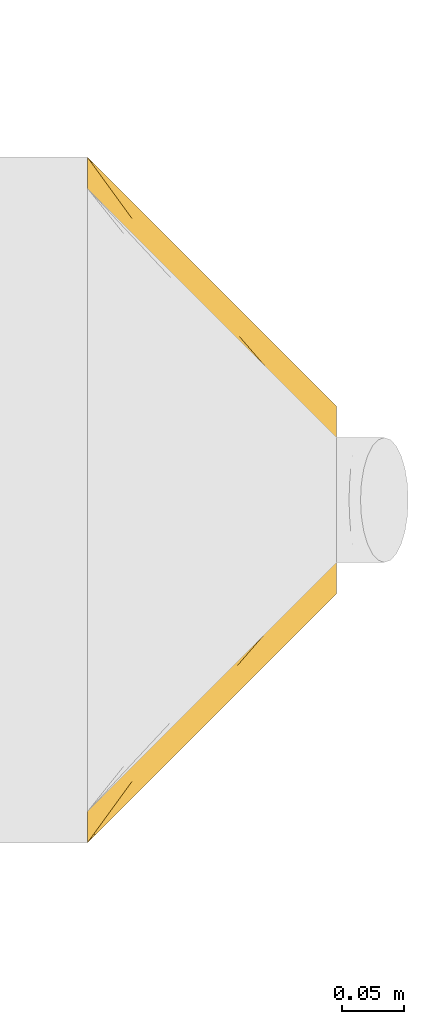
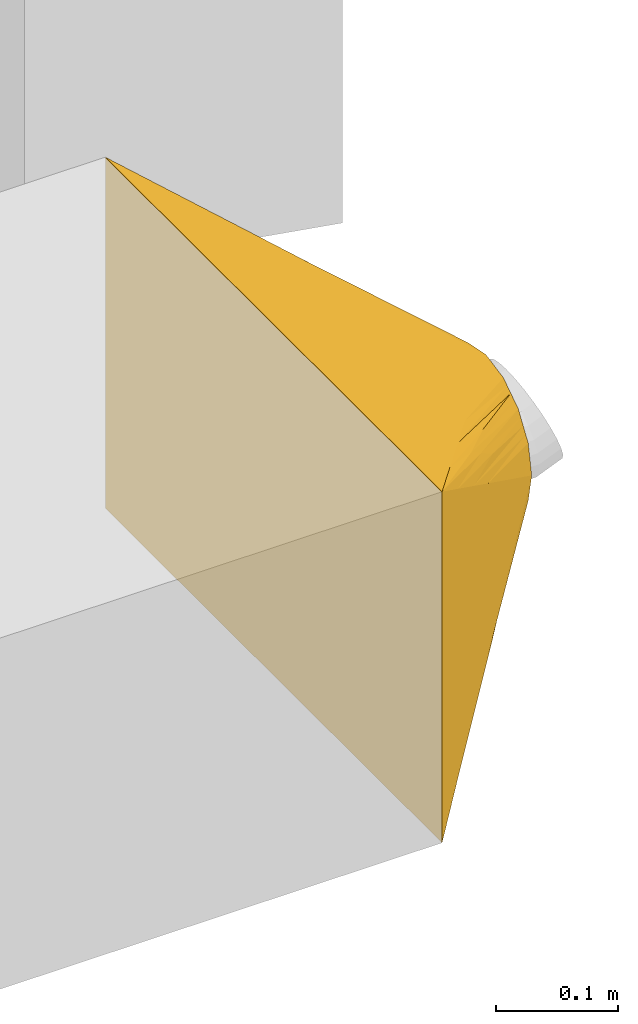
# One storey, part 2 of 44: 1 covering.
"""IFC2X3 building model written with IfcOpenShell, lengths in millimetres."""

from ifc_helpers import new_model, entity, si_unit, converted_unit, derived_unit, direction, frame, origin, place, context, subcontext, project, spatial, faceted_brep, element, save


model = new_model("IFC2X3")

# Units and contexts
model_context = context("Model", 3, precision=0.01, world=origin(), true_north=direction((6.12303176911189e-17, 1.0)))
body_context = subcontext(model_context, "Body", "Model", "MODEL_VIEW")
ifc_project = project(units=[si_unit("LENGTHUNIT", "METRE", prefix="MILLI"), si_unit("AREAUNIT", "SQUARE_METRE"), si_unit("VOLUMEUNIT", "CUBIC_METRE"), converted_unit("PLANEANGLEUNIT", "DEGREE", entity("IfcRatioMeasure", 0.0174532925199433), si_unit("PLANEANGLEUNIT", "RADIAN"), dimensions=[0, 0, 0, 0, 0, 0, 0]), si_unit("MASSUNIT", "GRAM", prefix="KILO"), derived_unit("MASSDENSITYUNIT", [(si_unit("MASSUNIT", "GRAM", prefix="KILO"), 1), (si_unit("LENGTHUNIT", "METRE"), -3)]), derived_unit("MOMENTOFINERTIAUNIT", [(si_unit("LENGTHUNIT", "METRE"), 4)]), si_unit("TIMEUNIT", "SECOND"), si_unit("FREQUENCYUNIT", "HERTZ"), si_unit("THERMODYNAMICTEMPERATUREUNIT", "DEGREE_CELSIUS"), derived_unit("THERMALTRANSMITTANCEUNIT", [(si_unit("MASSUNIT", "GRAM", prefix="KILO"), 1), (si_unit("THERMODYNAMICTEMPERATUREUNIT", "KELVIN"), -1), (si_unit("TIMEUNIT", "SECOND"), -3)]), derived_unit("VOLUMETRICFLOWRATEUNIT", [(si_unit("LENGTHUNIT", "METRE"), 3), (si_unit("TIMEUNIT", "SECOND"), -1)]), derived_unit("MASSFLOWRATEUNIT", [(si_unit("MASSUNIT", "GRAM", prefix="KILO"), 1), (si_unit("TIMEUNIT", "SECOND"), -1)]), derived_unit("ROTATIONALFREQUENCYUNIT", [(si_unit("TIMEUNIT", "SECOND"), -1)]), si_unit("ELECTRICCURRENTUNIT", "AMPERE"), si_unit("ELECTRICVOLTAGEUNIT", "VOLT"), si_unit("POWERUNIT", "WATT"), si_unit("FORCEUNIT", "NEWTON", prefix="KILO"), si_unit("ILLUMINANCEUNIT", "LUX"), si_unit("LUMINOUSFLUXUNIT", "LUMEN"), si_unit("LUMINOUSINTENSITYUNIT", "CANDELA"), derived_unit("USERDEFINED", [(si_unit("MASSUNIT", "GRAM", prefix="KILO"), -1), (si_unit("LENGTHUNIT", "METRE"), -2), (si_unit("TIMEUNIT", "SECOND"), 3), (si_unit("LUMINOUSFLUXUNIT", "LUMEN"), 1)]), derived_unit("LINEARVELOCITYUNIT", [(si_unit("LENGTHUNIT", "METRE"), 1), (si_unit("TIMEUNIT", "SECOND"), -1)]), si_unit("PRESSUREUNIT", "PASCAL"), derived_unit("USERDEFINED", [(si_unit("LENGTHUNIT", "METRE"), -2), (si_unit("MASSUNIT", "GRAM", prefix="KILO"), 1), (si_unit("TIMEUNIT", "SECOND"), -2)]), derived_unit("LINEARFORCEUNIT", [(si_unit("MASSUNIT", "GRAM", prefix="KILO"), 1), (si_unit("LENGTHUNIT", "METRE"), 1), (si_unit("TIMEUNIT", "SECOND"), -2), (si_unit("LENGTHUNIT", "METRE"), -1)]), derived_unit("PLANARFORCEUNIT", [(si_unit("MASSUNIT", "GRAM", prefix="KILO"), 1), (si_unit("LENGTHUNIT", "METRE"), 1), (si_unit("TIMEUNIT", "SECOND"), -2), (si_unit("LENGTHUNIT", "METRE"), -2)])], contexts=[model_context])

# Site, building, storey
site_placement = place(None, origin())
site = spatial("IfcSite", under=ifc_project, at=site_placement, CompositionType="ELEMENT")
building_placement = place(site_placement, origin())
building = spatial("IfcBuilding", under=site, at=building_placement, CompositionType="ELEMENT")
storey_placement = place(building_placement, frame((0.0, 0.0, 15900.0)))
storey = spatial("IfcBuildingStorey", under=building, at=storey_placement, CompositionType="ELEMENT", Elevation=15900.0)

# Covering
covering_placement = place(storey_placement, frame((23519.59, 14397.9, 3025.0)))
element("IfcCovering", 1, at=covering_placement, inside=storey, PredefinedType="INSULATION", context=body_context, shape_type="Brep", body=[
    faceted_brep([(200.0, 340.23, 209.78), (200.0, 336.16, 215.87), (200.0, 332.1, 221.95), (200.0, 328.03, 228.03), (200.0, 321.95, 232.1), (200.0, 315.87, 236.16), (200.0, 309.78, 240.23), (200.0, 303.7, 244.29), (200.0, 294.64, 246.09), (200.0, 284.82, 248.05), (200.0, 279.91, 249.02), (200.0, 275.0, 250.0), (200.0, 270.09, 249.02), (200.0, 265.18, 248.05), (200.0, 255.36, 246.09), (200.0, 246.3, 244.29), (200.0, 240.22, 240.23), (200.0, 234.13, 236.16), (200.0, 228.05, 232.1), (200.0, 221.97, 228.03), (200.0, 217.9, 221.95), (200.0, 213.84, 215.87), (200.0, 209.77, 209.78), (200.0, 205.71, 203.7), (200.0, 203.91, 194.64), (200.0, 201.95, 184.82), (200.0, 200.98, 179.91), (200.0, 200.0, 175.0), (200.0, 200.98, 170.09), (200.0, 201.95, 165.18), (200.0, 203.91, 155.36), (200.0, 205.71, 146.3), (200.0, 209.77, 140.22), (200.0, 213.84, 134.13), (200.0, 217.9, 128.05), (200.0, 221.97, 121.97), (200.0, 228.05, 117.9), (200.0, 234.13, 113.84), (200.0, 240.22, 109.77), (200.0, 246.3, 105.71), (200.0, 255.36, 103.91), (200.0, 265.18, 101.95), (200.0, 270.09, 100.98), (200.0, 275.0, 100.0), (200.0, 279.91, 100.98), (200.0, 284.82, 101.95), (200.0, 294.64, 103.91), (200.0, 303.7, 105.71), (200.0, 309.78, 109.77), (200.0, 315.87, 113.84), (200.0, 321.95, 117.9), (200.0, 328.03, 121.97), (200.0, 332.1, 128.05), (200.0, 336.16, 134.13), (200.0, 340.23, 140.22), (200.0, 344.29, 146.3), (200.0, 346.09, 155.36), (200.0, 348.05, 165.18), (200.0, 349.02, 170.09), (200.0, 350.0, 175.0), (200.0, 349.02, 179.91), (200.0, 348.05, 184.82), (200.0, 346.09, 194.64), (200.0, 344.29, 203.7), (0.0, 550.0, 350.0), (0.0, 550.0, 0.0), (0.0, 0.0, 0.0), (0.0, 0.0, 350.0), (70.49, 453.08, 35.25), (121.54, 406.44, 67.33), (82.87, 454.38, 47.42), (102.87, 408.56, 51.43), (183.81, 297.26, 91.91), (167.62, 319.52, 83.81), (135.25, 364.04, 67.62), (135.25, 414.75, 118.34), (167.62, 382.38, 146.67), (183.81, 366.19, 160.83), (102.87, 447.13, 90.01), (122.11, 421.17, 82.95), (100.0, 440.62, 62.7), (35.25, 514.75, 30.84), (70.49, 479.51, 61.68), (35.25, 501.54, 17.62), (35.25, 514.75, 319.16), (70.49, 479.51, 288.32), (102.87, 447.13, 259.99), (135.25, 414.75, 231.66), (167.62, 382.38, 203.33), (183.81, 366.19, 189.17), (121.54, 421.9, 267.21), (82.87, 461.15, 295.82), (135.25, 364.04, 282.38), (167.62, 319.52, 266.19), (183.81, 297.26, 258.09), (102.87, 408.56, 298.57), (122.11, 406.0, 282.22), (100.0, 437.3, 290.62), (35.25, 501.54, 332.38), (70.49, 453.08, 314.75), (35.25, 48.46, 332.38), (70.49, 96.92, 314.75), (102.87, 141.44, 298.57), (135.25, 185.96, 282.38), (167.62, 230.48, 266.19), (183.81, 252.74, 258.09), (121.54, 143.56, 282.67), (82.87, 95.62, 302.58), (135.25, 135.25, 231.66), (167.62, 167.62, 203.33), (183.81, 183.81, 189.17), (102.87, 102.87, 259.99), (122.11, 128.83, 267.05), (100.0, 109.38, 287.3), (35.25, 35.25, 319.16), (70.49, 70.49, 288.32), (35.25, 35.25, 30.84), (70.49, 70.49, 61.68), (102.87, 102.87, 90.01), (135.25, 135.25, 118.34), (167.62, 167.62, 146.67), (183.81, 183.81, 160.83), (121.54, 128.1, 82.79), (82.87, 88.85, 54.18), (135.25, 185.96, 67.62), (167.62, 230.48, 83.81), (183.81, 252.74, 91.91), (102.87, 141.44, 51.43), (122.11, 144.0, 67.78), (100.0, 112.7, 59.38), (35.25, 48.46, 17.62), (70.49, 96.92, 35.25)], [[[0, 1, 2, 3, 4, 5, 6, 7, 8, 9, 10, 11, 12, 13, 14, 15, 16, 17, 18, 19, 20, 21, 22, 23, 24, 25, 26, 27, 28, 29, 30, 31, 32, 33, 34, 35, 36, 37, 38, 39, 40, 41, 42, 43, 44, 45, 46, 47, 48, 49, 50, 51, 52, 53, 54, 55, 56, 57, 58, 59, 60, 61, 62, 63]], [[64, 65, 66, 67]], [[49, 68, 69]], [[69, 70, 50]], [[68, 48, 71]], [[72, 73, 74, 71, 47, 46, 45, 44, 43]], [[75, 76, 77, 59, 58, 57, 56, 55, 78]], [[79, 80, 81]], [[80, 79, 52]], [[49, 69, 50]], [[53, 79, 82]], [[81, 80, 65]], [[78, 54, 82]], [[69, 68, 83]], [[51, 50, 70]], [[65, 80, 70]], [[71, 48, 47]], [[70, 69, 83]], [[82, 79, 81]], [[52, 51, 80]], [[79, 53, 52]], [[65, 70, 83]], [[70, 80, 51]], [[68, 49, 48]], [[54, 78, 55]], [[54, 53, 82]], [[65, 64, 84, 85, 86, 87, 88, 89, 59, 77, 76, 75, 78, 82, 81]], [[1, 85, 90]], [[90, 91, 2]], [[85, 0, 86]], [[89, 88, 87, 86, 63, 62, 61, 60, 59]], [[92, 93, 94, 11, 10, 9, 8, 7, 95]], [[96, 97, 98]], [[97, 96, 4]], [[1, 90, 2]], [[5, 96, 99]], [[98, 97, 64]], [[95, 6, 99]], [[90, 85, 84]], [[3, 2, 91]], [[64, 97, 91]], [[86, 0, 63]], [[91, 90, 84]], [[99, 96, 98]], [[4, 3, 97]], [[96, 5, 4]], [[64, 91, 84]], [[91, 97, 3]], [[85, 1, 0]], [[6, 95, 7]], [[6, 5, 99]], [[64, 67, 100, 101, 102, 103, 104, 105, 11, 94, 93, 92, 95, 99, 98]], [[17, 101, 106]], [[106, 107, 18]], [[101, 16, 102]], [[105, 104, 103, 102, 15, 14, 13, 12, 11]], [[108, 109, 110, 27, 26, 25, 24, 23, 111]], [[112, 113, 114]], [[113, 112, 20]], [[17, 106, 18]], [[21, 112, 115]], [[114, 113, 67]], [[111, 22, 115]], [[106, 101, 100]], [[19, 18, 107]], [[67, 113, 107]], [[102, 16, 15]], [[107, 106, 100]], [[115, 112, 114]], [[20, 19, 113]], [[112, 21, 20]], [[67, 107, 100]], [[107, 113, 19]], [[101, 17, 16]], [[22, 111, 23]], [[22, 21, 115]], [[67, 66, 116, 117, 118, 119, 120, 121, 27, 110, 109, 108, 111, 115, 114]], [[33, 117, 122]], [[122, 123, 34]], [[117, 32, 118]], [[121, 120, 119, 118, 31, 30, 29, 28, 27]], [[124, 125, 126, 43, 42, 41, 40, 39, 127]], [[128, 129, 130]], [[129, 128, 36]], [[33, 122, 34]], [[37, 128, 131]], [[130, 129, 66]], [[127, 38, 131]], [[122, 117, 116]], [[35, 34, 123]], [[66, 129, 123]], [[118, 32, 31]], [[123, 122, 116]], [[131, 128, 130]], [[36, 35, 129]], [[128, 37, 36]], [[66, 123, 116]], [[123, 129, 35]], [[117, 33, 32]], [[38, 127, 39]], [[38, 37, 131]], [[66, 65, 83, 68, 71, 74, 73, 72, 43, 126, 125, 124, 127, 131, 130]]]),
])

save(model, "model.ifc")
